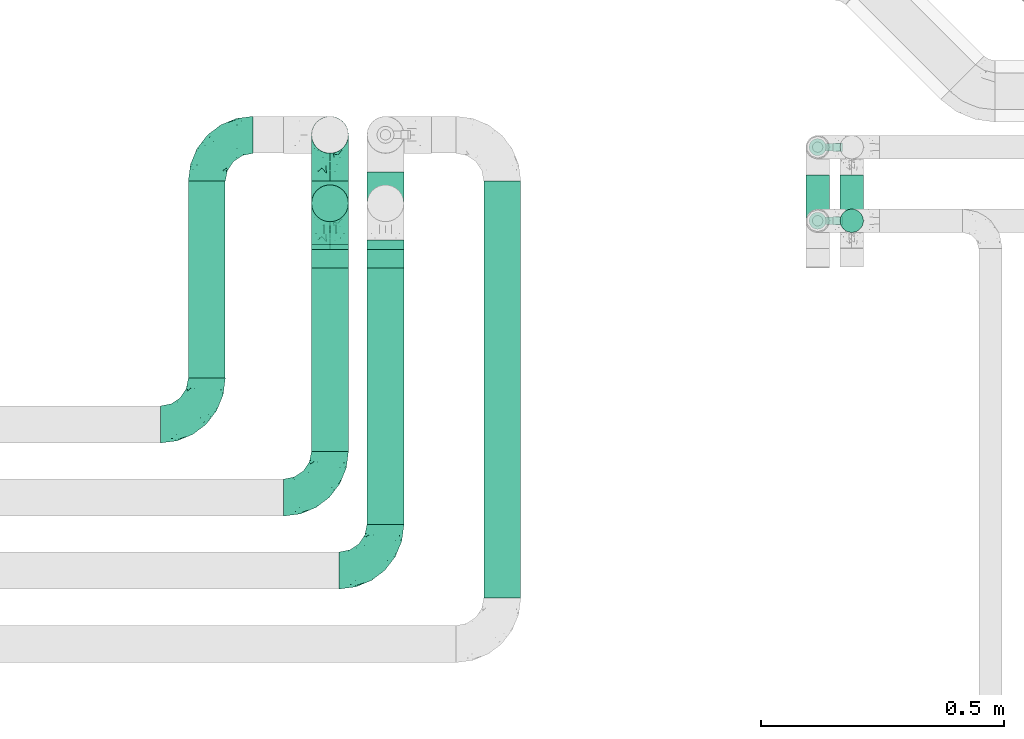
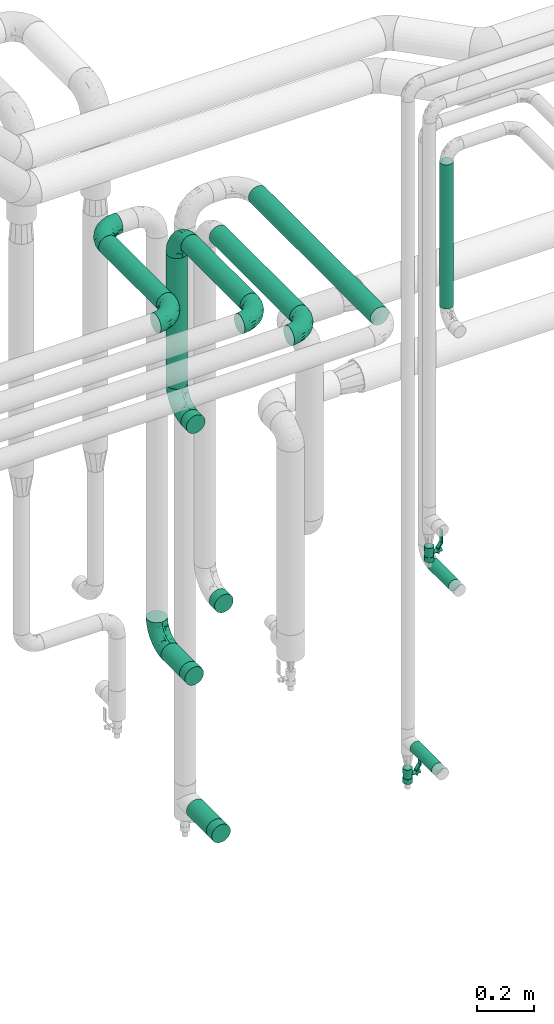
# One storey, part 677 of 827: 11 flow fittings, 10 flow segments, 2 flow controllers.
"""IFC2X3 building model written with IfcOpenShell, lengths in millimetres."""

from ifc_helpers import new_model, entity, si_unit, converted_unit, derived_unit, direction, frame, origin, origin_2d_with_axis, place, context, subcontext, project, spatial, polyline, circle, outline, extrude, faceted_brep, source, transform, mapped, material, material_list, type_object, type_shapes, element, save


model = new_model("IFC2X3")

# Units and contexts
model_context = context("Model", 3, precision=0.01, world=origin(), true_north=direction((6.12303176911189e-17, 1.0)))
body_context = subcontext(model_context, "Body", "Model", "MODEL_VIEW")
ifc_project = project(units=[si_unit("LENGTHUNIT", "METRE", prefix="MILLI"), si_unit("AREAUNIT", "SQUARE_METRE"), si_unit("VOLUMEUNIT", "CUBIC_METRE"), converted_unit("PLANEANGLEUNIT", "DEGREE", entity("IfcRatioMeasure", 0.0174532925199433), si_unit("PLANEANGLEUNIT", "RADIAN"), dimensions=[0, 0, 0, 0, 0, 0, 0]), si_unit("MASSUNIT", "GRAM", prefix="KILO"), derived_unit("MASSDENSITYUNIT", [(si_unit("MASSUNIT", "GRAM", prefix="KILO"), 1), (si_unit("LENGTHUNIT", "METRE"), -3)]), derived_unit("MOMENTOFINERTIAUNIT", [(si_unit("LENGTHUNIT", "METRE"), 4)]), si_unit("TIMEUNIT", "SECOND"), si_unit("FREQUENCYUNIT", "HERTZ"), si_unit("THERMODYNAMICTEMPERATUREUNIT", "DEGREE_CELSIUS"), derived_unit("THERMALTRANSMITTANCEUNIT", [(si_unit("MASSUNIT", "GRAM", prefix="KILO"), 1), (si_unit("THERMODYNAMICTEMPERATUREUNIT", "KELVIN"), -1), (si_unit("TIMEUNIT", "SECOND"), -3)]), derived_unit("VOLUMETRICFLOWRATEUNIT", [(si_unit("LENGTHUNIT", "METRE"), 3), (si_unit("TIMEUNIT", "SECOND"), -1)]), derived_unit("MASSFLOWRATEUNIT", [(si_unit("MASSUNIT", "GRAM", prefix="KILO"), 1), (si_unit("TIMEUNIT", "SECOND"), -1)]), derived_unit("ROTATIONALFREQUENCYUNIT", [(si_unit("TIMEUNIT", "SECOND"), -1)]), si_unit("ELECTRICCURRENTUNIT", "AMPERE"), si_unit("ELECTRICVOLTAGEUNIT", "VOLT"), si_unit("POWERUNIT", "WATT"), si_unit("FORCEUNIT", "NEWTON", prefix="KILO"), si_unit("ILLUMINANCEUNIT", "LUX"), si_unit("LUMINOUSFLUXUNIT", "LUMEN"), si_unit("LUMINOUSINTENSITYUNIT", "CANDELA"), derived_unit("USERDEFINED", [(si_unit("MASSUNIT", "GRAM", prefix="KILO"), -1), (si_unit("LENGTHUNIT", "METRE"), -2), (si_unit("TIMEUNIT", "SECOND"), 3), (si_unit("LUMINOUSFLUXUNIT", "LUMEN"), 1)]), derived_unit("LINEARVELOCITYUNIT", [(si_unit("LENGTHUNIT", "METRE"), 1), (si_unit("TIMEUNIT", "SECOND"), -1)]), si_unit("PRESSUREUNIT", "PASCAL"), derived_unit("USERDEFINED", [(si_unit("LENGTHUNIT", "METRE"), -2), (si_unit("MASSUNIT", "GRAM", prefix="KILO"), 1), (si_unit("TIMEUNIT", "SECOND"), -2)]), derived_unit("LINEARFORCEUNIT", [(si_unit("MASSUNIT", "GRAM", prefix="KILO"), 1), (si_unit("LENGTHUNIT", "METRE"), 1), (si_unit("TIMEUNIT", "SECOND"), -2), (si_unit("LENGTHUNIT", "METRE"), -1)]), derived_unit("PLANARFORCEUNIT", [(si_unit("MASSUNIT", "GRAM", prefix="KILO"), 1), (si_unit("LENGTHUNIT", "METRE"), 1), (si_unit("TIMEUNIT", "SECOND"), -2), (si_unit("LENGTHUNIT", "METRE"), -2)])], contexts=[model_context])

# Site, building, storey
site_placement = place(None, origin())
site = spatial("IfcSite", under=ifc_project, at=site_placement, CompositionType="ELEMENT")
building_placement = place(site_placement, origin())
building = spatial("IfcBuilding", under=site, at=building_placement, CompositionType="ELEMENT")
storey_placement = place(building_placement, frame((0.0, 0.0, 28200.0)))
storey = spatial("IfcBuildingStorey", under=building, at=storey_placement, Name="08", CompositionType="ELEMENT", Elevation=28200.0)

# Flow segments
pipe_segment_type = type_object("IfcPipeSegmentType", PredefinedType="NOTDEFINED")
flow_segment_1_placement = place(storey_placement, frame((47614.25, 18030.89, 374.4)))
element("IfcFlowSegment", 1, at=flow_segment_1_placement, inside=storey, type_object=pipe_segment_type, context=body_context, shape_type="SweptSolid", body=[
    extrude(circle(Radius=24.0, at=origin_2d_with_axis()), frame((25.6, 0.0, 25.6), z_axis=(0.0, 1.0, 0.0), x_axis=(-1.0, 0.0, 0.0)), (0.0, 0.0, 1.0), 153.000000000009),
])
flow_segment_2_placement = place(storey_placement, frame((47684.25, 18033.89, 1134.4)))
element("IfcFlowSegment", 2, at=flow_segment_2_placement, inside=storey, type_object=pipe_segment_type, context=body_context, shape_type="SweptSolid", body=[
    extrude(circle(Radius=24.0, at=origin_2d_with_axis()), frame((25.6, 0.0, 25.6), z_axis=(0.0, 1.0, 0.0), x_axis=(-1.0, 0.0, 0.0)), (0.0, 0.0, 1.0), 150.000000000001),
])
flow_segment_3_placement = place(storey_placement, frame((47684.25, 18064.04, 2325.61)))
element("IfcFlowSegment", 3, at=flow_segment_3_placement, inside=storey, type_object=pipe_segment_type, context=body_context, shape_type="SweptSolid", body=[
    extrude(circle(Radius=24.0, at=origin_2d_with_axis()), frame((25.6, 25.6, 0.0)), (0.0, 0.0, 1.0), 617.392358172253),
])
flow_segment_4_placement = place(storey_placement, frame((46952.73, 17315.24, 2960.65)))
element("IfcFlowSegment", 4, at=flow_segment_4_placement, inside=storey, type_object=pipe_segment_type, context=body_context, shape_type="SweptSolid", body=[
    extrude(circle(Radius=37.75, at=origin_2d_with_axis()), frame((39.35, 0.0, 39.35), z_axis=(0.0, 1.0, 0.0), x_axis=(1.0, 0.0, 0.0)), (0.0, 0.0, 1.0), 855.999999999981),
])
flow_segment_5_placement = place(storey_placement, frame((46712.73, 17466.24, 2960.65)))
element("IfcFlowSegment", 5, at=flow_segment_5_placement, inside=storey, type_object=pipe_segment_type, context=body_context, shape_type="SweptSolid", body=[
    extrude(circle(Radius=37.75, at=origin_2d_with_axis()), frame((39.35, 0.0, 39.35), z_axis=(0.0, 1.0, 0.0), x_axis=(1.0, 0.0, 0.0)), (0.0, 0.0, 1.0), 564.341537525472),
])
flow_segment_6_placement = place(storey_placement, frame((46598.69, 17616.04, 2960.65)))
element("IfcFlowSegment", 6, at=flow_segment_6_placement, inside=storey, type_object=pipe_segment_type, context=body_context, shape_type="SweptSolid", body=[
    extrude(circle(Radius=37.75, at=origin_2d_with_axis()), frame((39.35, 0.0, 39.35), z_axis=(0.0, 1.0, 0.0), x_axis=(1.0, 0.0, 0.0)), (0.0, 0.0, 1.0), 414.539387525502),
])
flow_segment_7_placement = place(storey_placement, frame((46345.69, 17766.24, 2960.65)))
element("IfcFlowSegment", 7, at=flow_segment_7_placement, inside=storey, type_object=pipe_segment_type, context=body_context, shape_type="SweptSolid", body=[
    extrude(circle(Radius=37.75, at=origin_2d_with_axis()), frame((39.35, 0.0, 39.35), z_axis=(0.0, 1.0, 0.0), x_axis=(1.0, 0.0, 0.0)), (0.0, 0.0, 1.0), 404.999999999995),
])
flow_segment_8_placement = place(storey_placement, frame((46712.73, 18050.24, 405.65)))
element("IfcFlowSegment", 8, at=flow_segment_8_placement, inside=storey, type_object=pipe_segment_type, context=body_context, shape_type="SweptSolid", body=[
    extrude(circle(Radius=37.75, at=origin_2d_with_axis()), frame((39.35, 0.0, 39.35), z_axis=(0.0, 1.0, 0.0), x_axis=(-1.0, 0.0, 0.0)), (0.0, 0.0, 1.0), 140.000000000001),
])
flow_segment_9_placement = place(storey_placement, frame((46598.69, 18086.23, 2345.05)))
element("IfcFlowSegment", 9, at=flow_segment_9_placement, inside=storey, type_object=pipe_segment_type, context=body_context, shape_type="SweptSolid", body=[
    extrude(circle(Radius=37.75, at=origin_2d_with_axis()), frame((39.35, 39.35, 0.0)), (0.0, 0.0, 1.0), 559.950000000011),
])
flow_segment_10_placement = place(storey_placement, frame((46598.69, 18040.85, 1125.65)))
element("IfcFlowSegment", 10, at=flow_segment_10_placement, inside=storey, type_object=pipe_segment_type, context=body_context, shape_type="SweptSolid", body=[
    extrude(circle(Radius=37.75, at=origin_2d_with_axis()), frame((39.35, 0.0, 39.35), z_axis=(0.0, 1.0, 0.0), x_axis=(1.0, 0.0, 0.0)), (0.0, 0.0, 1.0), 130.38628413926),
])

# Flow controllers
ifc_material = material()
ifc_material_list = material_list([ifc_material, ifc_material, ifc_material, ifc_material, ifc_material])
valve_type = type_object("IfcValveType", PredefinedType="NOTDEFINED", material=ifc_material_list)
shared_shape_1 = source(origin(), body_context, "Body", "SweptSolid", [
    extrude(circle(Radius=17.5, at=origin_2d_with_axis()), frame((-30.5, 0.0, 0.0), z_axis=(1.0, 0.0, 0.0), x_axis=(0.0, 1.0, 0.0)), (0.0, 0.0, 1.0), 20.3333333333333),
    extrude(circle(Radius=16.0, at=origin_2d_with_axis()), frame((-10.17, 0.0, 0.0), z_axis=(1.0, 0.0, 0.0), x_axis=(0.0, 1.0, 0.0)), (0.0, 0.0, 1.0), 20.3333333333333),
    extrude(circle(Radius=17.5, at=origin_2d_with_axis()), frame((10.17, 0.0, 0.0), z_axis=(1.0, 0.0, 0.0), x_axis=(0.0, 1.0, 0.0)), (0.0, 0.0, 1.0), 20.3333333333333),
    extrude(outline(polyline([(-38.75, -5.0), (-38.75, -10.0), (-17.92, -10.0), (2.08, 5.0), (56.25, 5.0), (56.25, 10.0), (0.42, 10.0), (-19.58, -5.0), (-38.75, -5.0)])), frame((28.75, -8.75, 41.5), z_axis=(0.0, -1.0, 0.0), x_axis=(1.0, 0.0, 0.0)), (0.0, 0.0, -1.0), 17.5),
    extrude(circle(Radius=8.0, at=origin_2d_with_axis()), origin(), (0.0, 0.0, 1.0), 49.0),
])
type_shapes(valve_type, [shared_shape_1])
for number, where, z_axis, x_axis in (
    (11, (47639.84, 18240.89, 247.5), (1.0, 0.0, 0.0), (0.0, 0.0, 1.0)),
    (12, (47639.84, 18089.64, 1289.0), (1.0, 0.0, 0.0), (0.0, 0.0, 1.0)),
):
    element("IfcFlowController", number, at=place(storey_placement, frame(where, z_axis=z_axis, x_axis=x_axis)), inside=storey, type_object=valve_type, material=ifc_material, context=body_context, shape_type="MappedRepresentation", body=[
        mapped(shared_shape_1, transform((0.0, 0.0, 0.0), scale=1.0)),
    ])

# Flow fittings
pipe_fitting_type_1 = type_object("IfcPipeFittingType", Name="ADSK_1", PredefinedType="NOTDEFINED", material=ifc_material)
shared_shape_2 = source(origin(), body_context, "Body", "SweptSolid", [
    extrude(circle(Radius=38.05, at=origin_2d_with_axis()), frame((0.0, 0.0, 0.0), z_axis=(1.0, 0.0, 0.0), x_axis=(0.0, 1.0, 0.0)), (0.0, 0.0, 1.0), 38.0000000000003),
])
type_shapes(pipe_fitting_type_1, [shared_shape_2])
for number, where, z_axis, x_axis, name in (
    (13, (46638.03, 18030.58, 2250.05), (-1.0, 0.0, 0.0), (0.0, -1.0, 0.0), "ADSK_1"),
    (14, (46752.07, 18030.58, 1442.25), (-1.0, 0.0, 0.0), (0.0, -1.0, 0.0), "ADSK_1"),
    (15, (46638.03, 18040.85, 1165.0), (0.0, 0.0, 1.0), (0.0, -1.0, 0.0), "ADSK_1"),
    (16, (46752.07, 18050.24, 445.0), (0.0, 0.0, 1.0), (0.0, -1.0, 0.0), "ADSK_1"),
):
    element("IfcFlowFitting", number, at=place(storey_placement, frame(where, z_axis=z_axis, x_axis=x_axis)), inside=storey, type_object=pipe_fitting_type_1, material=ifc_material, Name=name, ObjectType="ADSK_1", context=body_context, shape_type="MappedRepresentation", body=[
        mapped(shared_shape_2, transform((0.0, 0.0, 0.0), scale=1.0)),
    ])
pipe_fitting_type_2 = type_object("IfcPipeFittingType", Name="ADSK_1", PredefinedType="NOTDEFINED", material=ifc_material)
shared_shape_3 = source(origin(), body_context, "Body", "Brep", [
    faceted_brep([(-95.0, 19.02, -32.95), (-95.0, 9.85, -36.75), (-95.0, 0.0, -38.05), (-95.0, -9.85, -36.75), (-95.0, -19.03, -32.95), (-95.0, -26.91, -26.91), (-95.0, -32.95, -19.03), (-95.0, -36.75, -9.85), (-95.0, -38.05, 0.0), (-95.0, -36.75, 9.85), (-95.0, -32.95, 19.02), (-95.0, -26.91, 26.91), (-95.0, -19.03, 32.95), (-95.0, -9.85, 36.75), (-95.0, 0.0, 38.05), (-95.0, 9.85, 36.75), (-95.0, 19.02, 32.95), (-95.0, 26.91, 26.91), (-95.0, 32.95, 19.02), (-95.0, 36.75, 9.85), (-95.0, 38.05, 0.0), (-95.0, 36.75, -9.85), (-95.0, 32.95, -19.03), (-95.0, 26.91, -26.91), (0.0, 95.0, -38.05), (-9.85, 95.0, -36.75), (-19.02, 95.0, -32.95), (-26.91, 95.0, -26.91), (-32.95, 95.0, -19.03), (-36.75, 95.0, -9.85), (-38.05, 95.0, 0.0), (-36.75, 95.0, 9.85), (-32.95, 95.0, 19.02), (-26.91, 95.0, 26.91), (-19.02, 95.0, 32.95), (-9.85, 95.0, 36.75), (0.0, 95.0, 38.05), (9.85, 95.0, 36.75), (19.03, 95.0, 32.95), (26.91, 95.0, 26.91), (32.95, 95.0, 19.02), (36.75, 95.0, 9.85), (38.05, 95.0, 0.0), (36.75, 95.0, -9.85), (32.95, 95.0, -19.03), (26.91, 95.0, -26.91), (19.03, 95.0, -32.95), (9.85, 95.0, -36.75), (-7.99, -4.96, 6.3), (-0.92, 0.92, 0.0), (4.62, 8.1, 8.01), (-76.19, -35.57, 0.0), (-64.32, -32.32, 12.43), (20.51, 62.45, 28.68), (-60.56, -33.52, 0.0), (-70.4, -13.47, 34.42), (-39.61, -5.88, 32.32), (-49.6, 2.07, 37.1), (-70.34, -28.81, 21.71), (14.64, 40.81, 26.5), (5.88, 39.61, 32.32), (3.59, 20.77, 25.31), (-40.45, 68.06, 16.75), (-62.45, -20.51, 28.68), (-44.52, -26.87, 0.0), (-28.47, -20.22, 0.0), (-26.43, -17.83, 8.75), (-76.1, 39.63, 10.76), (-72.74, 37.58, 18.19), (-60.35, 46.18, 14.61), (-13.4, 13.4, 32.12), (-20.77, -3.59, 25.31), (-14.66, 81.47, 35.56), (-6.22, 71.26, 37.92), (-57.5, 42.48, 22.79), (-15.0, 34.74, 37.7), (-27.1, 12.08, 36.05), (-9.2, 28.81, 35.63), (-79.98, 23.7, 30.95), (-73.68, -4.3, 37.48), (-30.74, 21.67, 37.97), (-62.36, 47.59, 6.79), (-72.71, 32.83, 24.69), (-67.42, 7.02, 37.95), (-32.13, 75.27, 24.51), (-43.46, 51.47, 26.26), (-24.98, 73.15, 31.29), (20.59, 41.28, 19.85), (7.79, 16.09, 15.86), (-73.21, 42.39, 0.0), (-54.73, 54.73, 0.0), (-73.44, 15.79, 35.79), (-5.94, 4.32, 20.43), (28.81, 70.34, 21.71), (32.32, 64.32, 12.43), (-53.59, 26.2, 35.09), (-52.02, 19.31, 37.21), (21.38, 33.53, 10.34), (26.87, 44.52, 0.0), (-48.28, 12.14, 38.05), (4.3, 73.68, 37.48), (-44.08, -25.52, 12.79), (-41.28, -20.59, 19.85), (35.57, 76.19, 0.0), (-47.26, 54.3, 20.18), (-47.4, 61.99, 8.58), (-42.39, 73.21, 0.0), (-39.67, 78.86, 7.21), (-45.69, 36.84, 33.11), (-32.83, 50.13, 33.35), (13.47, 70.4, 34.42), (-18.25, 63.73, 36.07), (-40.63, -13.75, 27.22), (-16.63, 46.37, 37.95), (-53.47, 38.79, 28.59), (-26.07, 48.54, 36.15), (-34.51, 34.51, 36.86), (-2.07, 49.6, 37.1), (-22.79, -10.49, 19.23), (-61.73, 28.67, 31.87), (9.65, 14.7, 0.0), (20.22, 28.47, 0.0), (33.52, 60.56, 0.0), (-11.42, -5.44, 13.25), (-14.7, -9.65, 0.0), (-81.47, 14.66, -35.56), (-62.45, -20.51, -28.68), (-71.26, 6.22, -37.92), (-75.27, 32.13, -24.51), (-73.15, 24.98, -31.29), (13.47, 70.4, -34.42), (5.88, 39.61, -32.32), (-2.07, 49.6, -37.1), (-78.86, 39.67, -7.21), (-70.4, -13.47, -34.42), (-39.61, -5.88, -32.32), (-61.99, 47.4, -8.58), (32.32, 64.32, -12.43), (28.81, 70.34, -21.71), (-63.73, 18.25, -36.07), (-50.13, 32.83, -33.35), (4.3, 73.68, -37.48), (-7.02, 67.42, -37.95), (-39.63, 76.1, -10.76), (-46.18, 60.35, -14.61), (-47.59, 62.36, -6.79), (-64.32, -32.32, -12.43), (-26.2, 53.59, -35.09), (-15.79, 73.44, -35.79), (-19.31, 52.02, -37.21), (-37.58, 72.74, -18.19), (-70.34, -28.81, -21.71), (-42.48, 57.5, -22.79), (-38.79, 53.47, -28.59), (-51.47, 43.46, -26.26), (-32.83, 72.71, -24.69), (-46.37, 16.63, -37.95), (-73.68, -4.3, -37.48), (-41.28, -20.59, -19.85), (-44.08, -25.52, -12.79), (13.75, 40.63, -27.22), (20.51, 62.45, -28.68), (-68.06, 40.45, -16.75), (-54.3, 47.26, -20.18), (-12.14, 48.28, -38.05), (-21.67, 30.74, -37.97), (-36.84, 45.69, -33.11), (-11.42, -5.44, -13.25), (7.79, 16.09, -15.86), (4.62, 8.1, -8.01), (-23.7, 79.98, -30.95), (-26.43, -17.83, -8.75), (-7.99, -4.96, -6.3), (-40.81, -14.64, -26.5), (-20.77, -3.59, -25.31), (-34.74, 15.0, -37.7), (-12.08, 27.1, -36.05), (-28.81, 9.2, -35.63), (-22.79, -10.49, -19.23), (21.38, 33.53, -10.34), (20.59, 41.28, -19.85), (-48.54, 26.07, -36.15), (-49.6, 2.07, -37.1), (-13.4, 13.4, -32.12), (3.59, 20.77, -25.31), (-28.67, 61.73, -31.87), (-34.51, 34.51, -36.86), (-5.94, 4.32, -20.43)], [[[0, 1, 2, 3, 4, 5, 6, 7, 8, 9, 10, 11, 12, 13, 14, 15, 16, 17, 18, 19, 20, 21, 22, 23]], [[24, 25, 26, 27, 28, 29, 30, 31, 32, 33, 34, 35, 36, 37, 38, 39, 40, 41, 42, 43, 44, 45, 46, 47]], [[48, 49, 50]], [[51, 52, 9]], [[53, 39, 38]], [[9, 52, 10]], [[54, 52, 51]], [[55, 56, 57]], [[11, 10, 58]], [[59, 60, 61]], [[32, 31, 62]], [[63, 12, 11]], [[63, 55, 12]], [[64, 65, 66]], [[67, 68, 69]], [[70, 56, 71]], [[35, 72, 73]], [[69, 68, 74]], [[75, 76, 77]], [[16, 78, 17]], [[13, 79, 14]], [[76, 75, 80]], [[67, 69, 81]], [[18, 17, 82]], [[14, 79, 83]], [[20, 19, 67]], [[84, 85, 86]], [[87, 61, 88]], [[89, 81, 90]], [[18, 82, 68]], [[15, 91, 16]], [[14, 83, 15]], [[71, 92, 61]], [[17, 78, 82]], [[93, 87, 94]], [[95, 91, 96]], [[97, 98, 94]], [[86, 72, 34]], [[96, 99, 80]], [[37, 36, 100]], [[40, 39, 93]], [[40, 94, 41]], [[64, 66, 101]], [[93, 94, 40]], [[58, 102, 63]], [[94, 103, 41]], [[94, 87, 97]], [[104, 69, 74]], [[34, 33, 86]], [[105, 69, 104]], [[52, 58, 10]], [[106, 107, 30]], [[108, 109, 85]], [[105, 106, 90]], [[53, 110, 60]], [[86, 111, 72]], [[86, 109, 111]], [[33, 84, 86]], [[12, 55, 13]], [[112, 56, 63]], [[110, 38, 37]], [[34, 72, 35]], [[36, 35, 73]], [[111, 113, 73]], [[105, 107, 106]], [[110, 53, 38]], [[74, 114, 85]], [[91, 15, 83]], [[105, 90, 81]], [[107, 62, 31]], [[33, 32, 84]], [[115, 109, 116]], [[111, 115, 113]], [[100, 73, 117]], [[56, 55, 63]], [[79, 55, 57]], [[102, 118, 112]], [[56, 70, 76]], [[100, 110, 37]], [[117, 77, 60]], [[117, 60, 110]], [[60, 70, 61]], [[58, 52, 101]], [[63, 11, 58]], [[39, 53, 93]], [[87, 93, 53]], [[96, 91, 83]], [[78, 91, 119]], [[32, 62, 84]], [[84, 62, 104]], [[86, 85, 109]], [[85, 114, 108]], [[80, 113, 116]], [[117, 73, 113]], [[80, 116, 96]], [[80, 57, 76]], [[71, 112, 118]], [[61, 87, 59]], [[62, 107, 105]], [[97, 120, 121]], [[70, 71, 61]], [[71, 118, 92]], [[73, 100, 36]], [[110, 100, 117]], [[55, 79, 13]], [[83, 79, 57]], [[96, 83, 99]], [[116, 108, 95]], [[50, 97, 88]], [[97, 87, 88]], [[50, 49, 120]], [[122, 94, 98]], [[89, 20, 67]], [[105, 81, 69]], [[89, 67, 81]], [[68, 19, 18]], [[68, 67, 19]], [[74, 68, 82]], [[114, 82, 119]], [[74, 85, 104]], [[82, 114, 74]], [[114, 119, 108]], [[95, 108, 119]], [[116, 109, 108]], [[123, 48, 50]], [[97, 50, 120]], [[123, 50, 88]], [[91, 95, 119]], [[116, 95, 96]], [[84, 104, 85]], [[104, 62, 105]], [[83, 57, 99]], [[57, 80, 99]], [[66, 48, 123]], [[66, 124, 48]], [[118, 66, 123]], [[124, 66, 65]], [[66, 118, 101]], [[54, 64, 52]], [[124, 49, 48]], [[30, 107, 31]], [[91, 78, 16]], [[82, 78, 119]], [[56, 76, 57]], [[77, 76, 70]], [[60, 77, 70]], [[77, 117, 75]], [[117, 113, 75]], [[113, 80, 75]], [[9, 8, 51]], [[103, 94, 122]], [[103, 42, 41]], [[73, 72, 111]], [[113, 115, 116]], [[111, 109, 115]], [[102, 112, 63]], [[71, 56, 112]], [[118, 102, 101]], [[92, 123, 88]], [[123, 92, 118]], [[61, 92, 88]], [[87, 53, 59]], [[60, 59, 53]], [[97, 121, 98]], [[58, 101, 102]], [[64, 101, 52]], [[125, 1, 0]], [[126, 5, 4]], [[2, 1, 127]], [[1, 125, 127]], [[128, 129, 23]], [[130, 131, 132]], [[89, 133, 20]], [[126, 134, 135]], [[136, 89, 90]], [[137, 138, 44]], [[139, 129, 140]], [[24, 141, 142]], [[143, 144, 145]], [[125, 129, 139]], [[6, 146, 7]], [[147, 148, 149]], [[146, 51, 7]], [[143, 150, 144]], [[146, 6, 151]], [[152, 153, 154]], [[126, 4, 134]], [[0, 23, 129]], [[28, 155, 150]], [[43, 42, 103]], [[54, 146, 64]], [[139, 156, 127]], [[157, 3, 2]], [[151, 158, 159]], [[160, 131, 161]], [[22, 21, 162]], [[136, 144, 163]], [[149, 164, 165]], [[24, 142, 25]], [[166, 140, 154]], [[154, 129, 128]], [[143, 30, 29]], [[167, 168, 169]], [[155, 28, 27]], [[26, 170, 27]], [[171, 167, 172]], [[26, 25, 148]], [[27, 170, 155]], [[173, 135, 174]], [[144, 150, 152]], [[175, 176, 177]], [[24, 47, 141]], [[45, 161, 46]], [[148, 25, 142]], [[176, 175, 165]], [[64, 159, 171]], [[138, 45, 44]], [[130, 46, 161]], [[137, 44, 43]], [[178, 159, 158]], [[137, 103, 122]], [[163, 144, 152]], [[136, 133, 89]], [[103, 137, 43]], [[6, 5, 151]], [[178, 158, 173]], [[134, 4, 3]], [[178, 173, 174]], [[137, 98, 179]], [[145, 90, 106]], [[138, 180, 161]], [[46, 130, 47]], [[136, 90, 145]], [[133, 162, 21]], [[23, 22, 128]], [[139, 140, 181]], [[139, 181, 156]], [[157, 127, 182]], [[157, 134, 3]], [[182, 177, 135]], [[182, 135, 134]], [[135, 183, 174]], [[131, 130, 161]], [[141, 130, 132]], [[160, 180, 184]], [[131, 183, 176]], [[5, 126, 151]], [[158, 151, 126]], [[180, 138, 137]], [[161, 45, 138]], [[149, 148, 142]], [[170, 148, 185]], [[22, 162, 128]], [[128, 162, 163]], [[129, 154, 140]], [[154, 153, 166]], [[165, 156, 186]], [[182, 127, 156]], [[165, 186, 149]], [[165, 132, 176]], [[131, 184, 183]], [[187, 167, 178]], [[184, 168, 187]], [[167, 169, 172]], [[184, 180, 168]], [[174, 183, 184]], [[127, 157, 2]], [[134, 157, 182]], [[130, 141, 47]], [[142, 141, 132]], [[149, 142, 164]], [[186, 166, 147]], [[180, 179, 168]], [[169, 179, 120]], [[137, 179, 180]], [[179, 121, 120]], [[106, 30, 143]], [[136, 145, 144]], [[106, 143, 145]], [[150, 29, 28]], [[150, 143, 29]], [[152, 150, 155]], [[153, 155, 185]], [[152, 154, 163]], [[155, 153, 152]], [[153, 185, 166]], [[147, 166, 185]], [[186, 140, 166]], [[169, 120, 49]], [[169, 49, 172]], [[179, 169, 168]], [[148, 147, 185]], [[186, 147, 149]], [[128, 163, 154]], [[163, 162, 136]], [[142, 132, 164]], [[132, 165, 164]], [[171, 124, 65]], [[124, 171, 172]], [[64, 146, 159]], [[171, 159, 178]], [[171, 65, 64]], [[172, 49, 124]], [[162, 133, 136]], [[20, 133, 21]], [[148, 170, 26]], [[155, 170, 185]], [[131, 176, 132]], [[177, 176, 183]], [[135, 177, 183]], [[177, 182, 175]], [[182, 156, 175]], [[156, 165, 175]], [[51, 146, 54]], [[51, 8, 7]], [[129, 125, 0]], [[127, 125, 139]], [[140, 186, 181]], [[156, 181, 186]], [[158, 126, 173]], [[135, 173, 126]], [[187, 178, 174]], [[171, 178, 167]], [[184, 187, 174]], [[167, 187, 168]], [[180, 160, 161]], [[184, 131, 160]], [[98, 137, 122]], [[98, 121, 179]], [[151, 159, 146]]]),
])
type_shapes(pipe_fitting_type_2, [shared_shape_3])
for number, where, name in (
    (17, (46752.07, 17371.24, 3000.0), "ADSK_1"),
    (18, (46638.03, 17521.04, 3000.0), "ADSK_1"),
    (19, (46385.03, 17671.24, 3000.0), "ADSK_1"),
):
    element("IfcFlowFitting", number, at=place(storey_placement, frame(where)), inside=storey, type_object=pipe_fitting_type_2, material=ifc_material, Name=name, ObjectType="ADSK_1", context=body_context, shape_type="MappedRepresentation", body=[
        mapped(shared_shape_3, transform((0.0, 0.0, 0.0), scale=1.0)),
    ])
for number, where, z_axis, x_axis, name in (
    (20, (46638.03, 18125.58, 3000.0), (-1.0, 0.0, 0.0), (0.0, 1.0, 0.0), "ADSK_1"),
    (21, (46638.03, 18125.58, 2250.05), (-1.0, 0.0, 0.0), (0.0, 0.0, -1.0), "ADSK_1"),
    (22, (46638.03, 18266.24, 1165.0), (1.0, 0.0, 0.0), (0.0, 1.0, 0.0), "ADSK_1"),
    (23, (46385.03, 18266.24, 3000.0), (0.0, 0.0, 1.0), (-1.0, 0.0, 0.0), "ADSK_1"),
):
    element("IfcFlowFitting", number, at=place(storey_placement, frame(where, z_axis=z_axis, x_axis=x_axis)), inside=storey, type_object=pipe_fitting_type_2, material=ifc_material, Name=name, ObjectType="ADSK_1", context=body_context, shape_type="MappedRepresentation", body=[
        mapped(shared_shape_3, transform((0.0, 0.0, 0.0), scale=1.0)),
    ])

save(model, "model.ifc")
